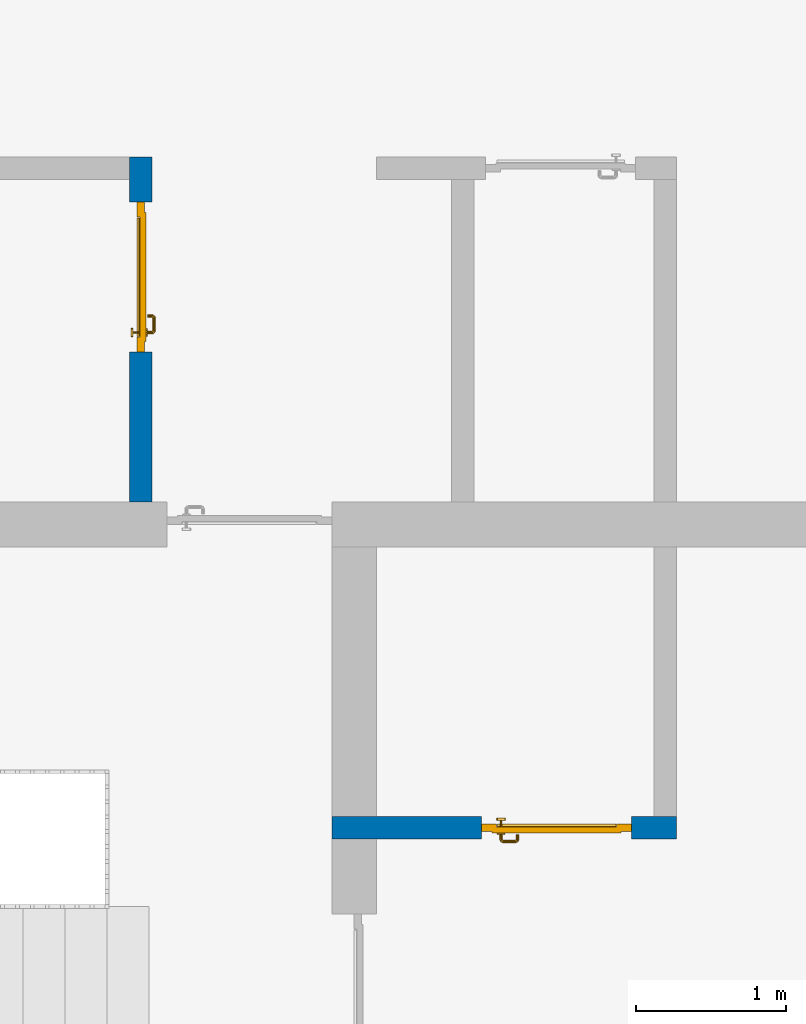
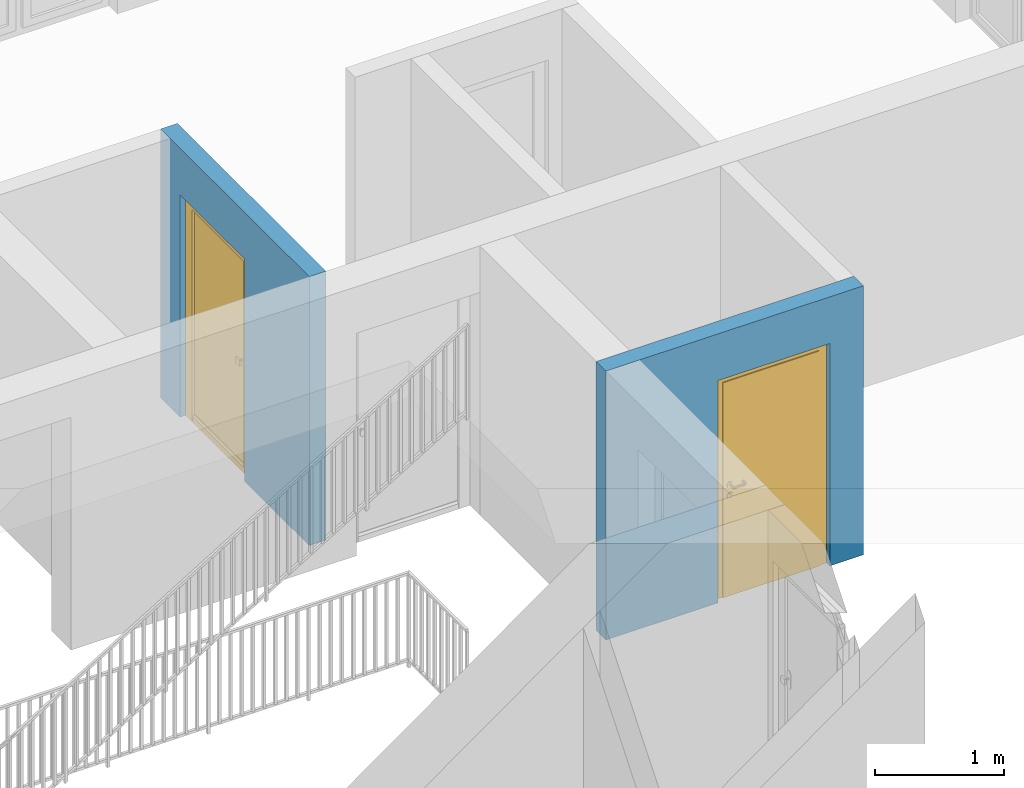
# One storey, part 16 of 48: 2 doors, 2 walls, 2 openings.
"""IFC4 building model written with IfcOpenShell, lengths in metres."""

from ifc_helpers import new_model, entity, si_unit, converted_unit, derived_unit, direction, frame, origin_with_axes, place, context, subcontext, project, spatial, polygons, source, transform, mapped, material, type_object, element, fill, save


model = new_model("IFC4")

# Units and contexts
model_context = context("Model", 3, precision=1e-05, world=origin_with_axes(), true_north=direction((0.0, 1.0)))
body_context = subcontext(model_context, "Body", "Model", "MODEL_VIEW")
ifc_project = project(units=[si_unit("LENGTHUNIT", "METRE"), si_unit("AREAUNIT", "SQUARE_METRE"), si_unit("VOLUMEUNIT", "CUBIC_METRE"), converted_unit("PLANEANGLEUNIT", "DEGREE", entity("IfcPlaneAngleMeasure", 0.0174532925199), si_unit("PLANEANGLEUNIT", "RADIAN"), dimensions=[0, 0, 0, 0, 0, 0, 0]), converted_unit("TIMEUNIT", "Year", entity("IfcTimeMeasure", 31556926.0), si_unit("TIMEUNIT", "SECOND"), dimensions=[0, 0, 1, 0, 0, 0, 0]), si_unit("MASSUNIT", "GRAM", prefix="KILO"), si_unit("THERMODYNAMICTEMPERATUREUNIT", "DEGREE_CELSIUS"), si_unit("LUMINOUSINTENSITYUNIT", "LUMEN"), si_unit("ENERGYUNIT", "JOULE", prefix="MEGA"), derived_unit("THERMALCONDUCTANCEUNIT", [(si_unit("POWERUNIT", "WATT"), 1), (si_unit("LENGTHUNIT", "METRE"), -1), (si_unit("THERMODYNAMICTEMPERATUREUNIT", "KELVIN"), -1)]), derived_unit("SPECIFICHEATCAPACITYUNIT", [(si_unit("ENERGYUNIT", "JOULE"), 1), (si_unit("MASSUNIT", "GRAM", prefix="KILO"), -1), (si_unit("THERMODYNAMICTEMPERATUREUNIT", "KELVIN"), -1)]), derived_unit("MASSDENSITYUNIT", [(si_unit("MASSUNIT", "GRAM", prefix="KILO"), 1), (si_unit("VOLUMEUNIT", "CUBIC_METRE"), -1)])], contexts=[model_context])

# Site, building, storey
site_placement = place(None, origin_with_axes())
site = spatial("IfcSite", under=ifc_project, at=site_placement, CompositionType="ELEMENT")
building_placement = place(site_placement, origin_with_axes())
building = spatial("IfcBuilding", under=site, at=building_placement, CompositionType="ELEMENT")
storey_placement = place(building_placement, frame((0.0, 0.0, 3.4), z_axis=(0.0, 0.0, 1.0), x_axis=(1.0, 0.0, 0.0)))
storey = spatial("IfcBuildingStorey", under=building, at=storey_placement, Name="1. Geschoss", CompositionType="ELEMENT", Elevation=3.4)

# Wall, opening, door
ifc_material = material()
wall_type = type_object("IfcWallType", Name="150", PredefinedType="NOTDEFINED")
wall_1_placement = place(storey_placement, frame((1.3378006196, 1.37118776896, 0.0), z_axis=(0.0, 0.0, 1.0), x_axis=(0.0, 1.0, 0.0)))
wall_1 = element("IfcWall", 1, at=wall_1_placement, inside=storey, type_object=wall_type, material=ifc_material, Name="Wand-002", PredefinedType="NOTDEFINED", context=body_context, shape_type="Tessellation", body=[
    polygons([(1.3, 0.0, 0.0), (1.3, 0.0, 2.1), (2.3, 0.0, 2.1), (2.3, 0.0, 0.0), (2.6, 0.0, 0.0), (2.6, 0.0, 2.54), (0.3, 0.0, 2.54), (0.3, 0.0, 0.0), (1.3, 0.1, 0.0), (1.3, 0.1, 2.1), (2.3, 0.1, 2.1), (2.3, 0.1, 0.0), (2.3, 0.15, 0.0), (2.6, 0.15, 0.0), (2.6, 0.15, 2.54), (0.3, 0.15, 2.54), (0.3, 0.15, 0.0), (1.3, 0.15, 0.0), (1.3, 0.15, 2.1), (2.3, 0.15, 2.1)], [[[1, 2, 3, 4, 5, 6, 7, 8]], [[2, 1, 9, 10]], [[3, 2, 10, 11]], [[4, 3, 11, 12]], [[4, 12, 13, 14, 5]], [[6, 5, 14, 15]], [[6, 15, 16, 7]], [[16, 17, 8, 7]], [[9, 1, 8, 17, 18]], [[10, 9, 18, 19]], [[11, 10, 19, 20]], [[12, 11, 20, 13]], [[14, 13, 20, 19, 18, 17, 16, 15]]], closed=True),
])
opening_1_placement = place(wall_1_placement, frame((1.8, 0.0, 0.0), z_axis=(0.0, 0.0, 1.0), x_axis=(1.0, 0.0, 0.0)))
opening_1 = element("IfcOpeningElement", 2, at=opening_1_placement, cuts=wall_1, context=body_context, identifier="Reference", shape_type="Tessellation", body=[
    polygons([(-0.5, 0.1, 0.0), (-0.5, 0.1, 2.1), (-0.5, 0.151, 2.1), (-0.5, 0.151, 0.0), (-0.5, -0.001, 0.0), (-0.5, -0.001, 2.1), (0.5, 0.1, 2.1), (0.5, 0.151, 2.1), (0.5, -0.001, 2.1), (0.5, 0.151, 0.0), (0.5, 0.1, 0.0), (0.5, -0.001, 0.0)], [[[1, 2, 3, 4]], [[2, 1, 5, 6]], [[7, 8, 3, 2, 6, 9]], [[8, 10, 4, 3]], [[1, 4, 10, 11, 12, 5]], [[6, 5, 12, 9]], [[7, 11, 10, 8]], [[11, 7, 9, 12]]], closed=True),
])
door_type = type_object("IfcDoorType", Name="Eingang 01 1-Fl 26", OperationType="SINGLE_SWING_LEFT", PredefinedType="DOOR")
shared_shape = source(origin_with_axes(), body_context, "Body", "Tessellation", [
    polygons([(-0.5, -0.05, 0.0), (-0.5, -0.05, 2.1), (-0.5, -0.03, 2.1), (-0.5, -0.03, 0.0), (-0.4, -0.05, 0.0), (-0.4, -0.05, 2.0), (-0.1301, -0.05, 2.0), (-0.0001, -0.05, 2.0), (0.4, -0.05, 2.0), (0.4, -0.05, 0.0), (0.5, -0.05, 0.0), (0.5, -0.05, 2.1), (0.5, -0.03, 2.1), (0.5, -0.03, 0.0), (0.4, -0.03, 0.0), (0.4, -0.03, 2.0), (-0.0001, -0.03, 2.0), (-0.1301, -0.03, 2.0), (-0.4, -0.03, 2.0), (-0.4, -0.03, 0.0)], [[[1, 2, 3, 4]], [[1, 5, 6, 7, 8, 9, 10, 11, 12, 2]], [[2, 12, 13, 3]], [[4, 3, 13, 14, 15, 16, 17, 18, 19, 20]], [[5, 1, 4, 20]], [[6, 5, 20, 19]], [[7, 6, 19, 18]], [[8, 7, 18, 17]], [[9, 8, 17, 16]], [[10, 9, 16, 15]], [[11, 10, 15, 14]], [[12, 11, 14, 13]]], closed=True),
    polygons([(-0.5, -0.03, 0.0), (-0.5, -0.03, 2.1), (-0.5, 0.0, 2.1), (-0.5, 0.0, 0.0), (-0.43, -0.03, 0.0), (-0.43, -0.03, 2.03), (-0.1001, -0.03, 2.03), (-0.0301, -0.03, 2.03), (0.43, -0.03, 2.03), (0.43, -0.03, 0.0), (0.5, -0.03, 0.0), (0.5, -0.03, 2.1), (0.5, 0.0, 2.1), (0.5, 0.0, 0.0), (0.43, 0.0, 0.0), (0.43, 0.0, 2.03), (-0.0301, 0.0, 2.03), (-0.1001, 0.0, 2.03), (-0.43, 0.0, 2.03), (-0.43, 0.0, 0.0)], [[[1, 2, 3, 4]], [[1, 5, 6, 7, 8, 9, 10, 11, 12, 2]], [[2, 12, 13, 3]], [[4, 3, 13, 14, 15, 16, 17, 18, 19, 20]], [[5, 1, 4, 20]], [[6, 5, 20, 19]], [[7, 6, 19, 18]], [[8, 7, 18, 17]], [[9, 8, 17, 16]], [[10, 9, 16, 15]], [[11, 10, 15, 14]], [[12, 11, 14, 13]]], closed=True),
    polygons([(-0.43, 0.01, 0.0), (-0.43, 0.01, 2.03), (0.43, 0.01, 2.03), (0.43, 0.01, 0.0), (-0.43, -0.03, 0.0), (-0.43, -0.03, 2.03), (0.43, -0.03, 2.03), (0.43, -0.03, 0.0)], [[[1, 2, 3, 4]], [[1, 5, 6, 2]], [[2, 6, 7, 3]], [[3, 7, 8, 4]], [[4, 8, 5, 1]], [[8, 7, 6, 5]]], closed=True),
    polygons([(-0.395, -0.05, 0.0), (0.395, -0.05, 0.0), (0.395, -0.05, 0.05), (-0.395, -0.05, 0.05), (-0.395, -0.03, 0.0), (0.395, -0.03, 0.0), (0.395, -0.03, 0.07), (0.395, -0.035, 0.07), (-0.395, -0.035, 0.07), (-0.395, -0.03, 0.07)], [[[1, 2, 3, 4]], [[5, 6, 2, 1]], [[2, 6, 7, 8, 3]], [[4, 3, 8, 9]], [[1, 4, 9, 10, 5]], [[10, 7, 6, 5]], [[9, 8, 7, 10]]], closed=True),
    polygons([(0.3835, 0.02, 1.0733826859), (0.37, 0.02, 1.077), (0.37, 0.0199, 1.077), (0.3835, 0.0199, 1.0733826859), (0.393382685902, 0.02, 1.0635), (0.397, 0.02, 1.05), (0.393382685902, 0.02, 1.0365), (0.3835, 0.02, 1.0266173141), (0.37, 0.02, 1.023), (0.3565, 0.02, 1.0266173141), (0.346617314098, 0.02, 1.0365), (0.343, 0.02, 1.05), (0.346617314098, 0.02, 1.0635), (0.3565, 0.02, 1.0733826859), (0.3565, 0.0199, 1.0733826859), (0.37, 0.0101, 1.077), (0.3835, 0.0101, 1.0733826859), (0.393382685902, 0.0199, 1.0635), (0.397, 0.0199, 1.05), (0.393382685902, 0.0199, 1.0365), (0.3835, 0.0199, 1.0266173141), (0.37, 0.0199, 1.023), (0.3565, 0.0199, 1.0266173141), (0.346617314098, 0.0199, 1.0365), (0.343, 0.0199, 1.05), (0.346617314098, 0.0199, 1.0635), (0.3565, 0.0101, 1.0733826859), (0.37, 0.01, 1.077), (0.3835, 0.01, 1.0733826859), (0.393382685902, 0.0101, 1.0635), (0.397, 0.0101, 1.05), (0.393382685902, 0.0101, 1.0365), (0.3835, 0.0101, 1.0266173141), (0.37, 0.0101, 1.023), (0.3565, 0.0101, 1.0266173141), (0.346617314098, 0.0101, 1.0365), (0.343, 0.0101, 1.05), (0.346617314098, 0.0101, 1.0635), (0.3565, 0.01, 1.0733826859), (0.346617314098, 0.01, 1.0635), (0.343, 0.01, 1.05), (0.346617314098, 0.01, 1.0365), (0.3565, 0.01, 1.0266173141), (0.37, 0.01, 1.023), (0.3835, 0.01, 1.0266173141), (0.393382685902, 0.01, 1.0365), (0.397, 0.01, 1.05), (0.393382685902, 0.01, 1.0635)], [[[1, 2, 3, 4]], [[2, 1, 5, 6, 7, 8, 9, 10, 11, 12, 13, 14]], [[2, 14, 15, 3]], [[4, 3, 16, 17]], [[5, 1, 4, 18]], [[6, 5, 18, 19]], [[7, 6, 19, 20]], [[8, 7, 20, 21]], [[9, 8, 21, 22]], [[10, 9, 22, 23]], [[11, 10, 23, 24]], [[12, 11, 24, 25]], [[13, 12, 25, 26]], [[14, 13, 26, 15]], [[3, 15, 27, 16]], [[17, 16, 28, 29]], [[18, 4, 17, 30]], [[19, 18, 30, 31]], [[20, 19, 31, 32]], [[21, 20, 32, 33]], [[22, 21, 33, 34]], [[23, 22, 34, 35]], [[24, 23, 35, 36]], [[25, 24, 36, 37]], [[26, 25, 37, 38]], [[15, 26, 38, 27]], [[16, 27, 39, 28]], [[28, 39, 40, 41, 42, 43, 44, 45, 46, 47, 48, 29]], [[30, 17, 29, 48]], [[31, 30, 48, 47]], [[32, 31, 47, 46]], [[33, 32, 46, 45]], [[34, 33, 45, 44]], [[35, 34, 44, 43]], [[36, 35, 43, 42]], [[37, 36, 42, 41]], [[38, 37, 41, 40]], [[27, 38, 40, 39]]], closed=True),
    polygons([(0.362532169224, 0.019, 0.959692280177), (0.363279754556, 0.019, 0.961639806549), (0.35705, 0.019, 0.972430057958), (0.347569942042, 0.019, 0.96295), (0.365, 0.019, 0.952886751346), (0.365, 0.019, 0.9544), (0.362532169224, 0.02, 0.959692280177), (0.363279754556, 0.02, 0.961639806549), (0.364624817685, 0.02, 0.965143815798), (0.364624817685, 0.019, 0.965143815798), (0.37, 0.019, 0.967425445323), (0.37, 0.019, 0.9759), (0.357, 0.019, 0.972516660498), (0.347483339502, 0.019, 0.963), (0.365, 0.019, 0.95), (0.3441, 0.019, 0.95), (0.365, 0.019, 0.947113248654), (0.365, 0.019, 0.941339745962), (0.365, 0.019, 0.9375), (0.365, 0.02, 0.9375), (0.365, 0.02, 0.941339745962), (0.365, 0.02, 0.947113248654), (0.365, 0.02, 0.95), (0.365, 0.02, 0.952886751346), (0.365, 0.02, 0.9544), (0.346703916638, 0.02, 0.96345), (0.35655, 0.02, 0.973296083362), (0.37, 0.02, 0.9769), (0.37, 0.02, 0.967425445323), (0.375375182315, 0.019, 0.965143815798), (0.376720245444, 0.019, 0.961639806549), (0.38295, 0.019, 0.972430057958), (0.37, 0.019, 0.976), (0.357, 0.0189, 0.972516660498), (0.347483339502, 0.0189, 0.963), (0.344, 0.019, 0.95), (0.347569942042, 0.019, 0.93705), (0.35705, 0.019, 0.927569942042), (0.37, 0.019, 0.9241), (0.37, 0.019, 0.9325), (0.366464466094, 0.019, 0.933964466094), (0.366464466094, 0.02, 0.933964466094), (0.37, 0.02, 0.9231), (0.35655, 0.02, 0.926703916638), (0.37, 0.02, 0.9325), (0.346703916638, 0.02, 0.93655), (0.3431, 0.02, 0.95), (0.346617314098, 0.02, 0.9635), (0.3565, 0.02, 0.973382685902), (0.37, 0.02, 0.977), (0.375375182315, 0.02, 0.965143815798), (0.38345, 0.02, 0.973296083362), (0.376720245444, 0.02, 0.961639806549), (0.377467830776, 0.02, 0.959692280177), (0.377467830776, 0.019, 0.959692280177), (0.375, 0.019, 0.9544), (0.375, 0.019, 0.952886751346), (0.392430057958, 0.019, 0.96295), (0.383, 0.019, 0.972516660498), (0.37, 0.0189, 0.976), (0.357, 0.0101, 0.972516660498), (0.347483339502, 0.0101, 0.963), (0.344, 0.0189, 0.95), (0.347483339502, 0.019, 0.937), (0.357, 0.019, 0.927483339502), (0.37, 0.019, 0.924), (0.38295, 0.019, 0.927569942042), (0.375, 0.019, 0.941339745962), (0.375, 0.019, 0.9375), (0.373535533906, 0.019, 0.933964466094), (0.37, 0.02, 0.923), (0.3565, 0.02, 0.926617314098), (0.38345, 0.02, 0.926703916638), (0.373535533906, 0.02, 0.933964466094), (0.375, 0.02, 0.9375), (0.375, 0.02, 0.941339745962), (0.346617314098, 0.02, 0.9365), (0.343, 0.02, 0.95), (0.346617314098, 0.0199, 0.9635), (0.3565, 0.0199, 0.973382685902), (0.37, 0.0199, 0.977), (0.3835, 0.02, 0.973382685902), (0.393296083362, 0.02, 0.96345), (0.375, 0.02, 0.952886751346), (0.375, 0.02, 0.9544), (0.375, 0.02, 0.95), (0.375, 0.02, 0.947113248654), (0.375, 0.019, 0.947113248654), (0.375, 0.019, 0.95), (0.3959, 0.019, 0.95), (0.392516660498, 0.019, 0.963), (0.383, 0.0189, 0.972516660498), (0.37, 0.0101, 0.976), (0.357, 0.01, 0.972516660498), (0.347483339502, 0.01, 0.963), (0.344, 0.0101, 0.95), (0.347483339502, 0.0189, 0.937), (0.357, 0.0189, 0.927483339502), (0.37, 0.0189, 0.924), (0.383, 0.019, 0.927483339502), (0.392430057958, 0.019, 0.93705), (0.37, 0.0199, 0.923), (0.3565, 0.0199, 0.926617314098), (0.3835, 0.02, 0.926617314098), (0.393296083362, 0.02, 0.93655), (0.346617314098, 0.0199, 0.9365), (0.343, 0.0199, 0.95), (0.346617314098, 0.0101, 0.9635), (0.3565, 0.0101, 0.973382685902), (0.37, 0.0101, 0.977), (0.3835, 0.0199, 0.973382685902), (0.393382685902, 0.02, 0.9635), (0.3969, 0.02, 0.95), (0.396, 0.019, 0.95), (0.392516660498, 0.0189, 0.963), (0.383, 0.0101, 0.972516660498), (0.37, 0.01, 0.976), (0.35695, 0.01, 0.972603263039), (0.347396736961, 0.01, 0.96305), (0.344, 0.01, 0.95), (0.347483339502, 0.0101, 0.937), (0.357, 0.0101, 0.927483339502), (0.37, 0.0101, 0.924), (0.383, 0.0189, 0.927483339502), (0.392516660498, 0.019, 0.937), (0.37, 0.0101, 0.923), (0.3565, 0.0101, 0.926617314098), (0.3835, 0.0199, 0.926617314098), (0.393382685902, 0.02, 0.9365), (0.346617314098, 0.0101, 0.9365), (0.343, 0.0101, 0.95), (0.346617314098, 0.01, 0.9635), (0.3565, 0.01, 0.973382685902), (0.37, 0.01, 0.977), (0.3835, 0.0101, 0.973382685902), (0.393382685902, 0.0199, 0.9635), (0.397, 0.02, 0.95), (0.396, 0.0189, 0.95), (0.392516660498, 0.0101, 0.963), (0.383, 0.01, 0.972516660498), (0.37, 0.01, 0.9761), (0.35655, 0.01, 0.973296083362), (0.346703916638, 0.01, 0.96345), (0.3439, 0.01, 0.95), (0.347483339502, 0.01, 0.937), (0.357, 0.01, 0.927483339502), (0.37, 0.01, 0.924), (0.383, 0.0101, 0.927483339502), (0.392516660498, 0.0189, 0.937), (0.37, 0.01, 0.923), (0.3565, 0.01, 0.926617314098), (0.3835, 0.0101, 0.926617314098), (0.393382685902, 0.0199, 0.9365), (0.346617314098, 0.01, 0.9365), (0.343, 0.01, 0.95), (0.37, 0.01, 0.9769), (0.3835, 0.01, 0.973382685902), (0.393382685902, 0.0101, 0.9635), (0.397, 0.0199, 0.95), (0.396, 0.0101, 0.95), (0.392516660498, 0.01, 0.963), (0.38305, 0.01, 0.972603263039), (0.3431, 0.01, 0.95), (0.347396736961, 0.01, 0.93695), (0.35695, 0.01, 0.927396736961), (0.37, 0.01, 0.9239), (0.383, 0.01, 0.927483339502), (0.392516660498, 0.0101, 0.937), (0.37, 0.01, 0.9231), (0.35655, 0.01, 0.926703916638), (0.3835, 0.01, 0.926617314098), (0.393382685902, 0.0101, 0.9365), (0.346703916638, 0.01, 0.93655), (0.38345, 0.01, 0.973296083362), (0.393382685902, 0.01, 0.9635), (0.397, 0.0101, 0.95), (0.396, 0.01, 0.95), (0.392603263039, 0.01, 0.96305), (0.38305, 0.01, 0.927396736961), (0.392516660498, 0.01, 0.937), (0.38345, 0.01, 0.926703916638), (0.393382685902, 0.01, 0.9365), (0.393296083362, 0.01, 0.96345), (0.397, 0.01, 0.95), (0.3961, 0.01, 0.95), (0.392603263039, 0.01, 0.93695), (0.393296083362, 0.01, 0.93655), (0.3969, 0.01, 0.95)], [[[1, 2, 3, 4, 5, 6]], [[1, 7, 8, 9, 10, 2]], [[10, 11, 12, 3, 2]], [[4, 3, 13, 14]], [[15, 5, 4, 16]], [[6, 5, 15, 17, 18, 19, 20, 21, 22, 23, 24, 25]], [[6, 25, 7, 1]], [[7, 25, 24, 26, 27, 8]], [[9, 8, 27, 28, 29]], [[10, 9, 29, 11]], [[30, 31, 32, 12, 11]], [[3, 12, 33, 13]], [[14, 13, 34, 35]], [[16, 4, 14, 36]], [[17, 15, 16, 37]], [[18, 17, 37, 38]], [[38, 39, 40, 41, 19, 18]], [[19, 41, 42, 20]], [[43, 44, 21, 20, 42, 45]], [[22, 21, 44, 46]], [[23, 22, 46, 47]], [[24, 23, 47, 26]], [[48, 49, 27, 26]], [[49, 50, 28, 27]], [[51, 29, 28, 52, 53]], [[11, 29, 51, 30]], [[30, 51, 53, 54, 55, 31]], [[55, 56, 57, 58, 32, 31]], [[12, 32, 59, 33]], [[13, 33, 60, 34]], [[35, 34, 61, 62]], [[36, 14, 35, 63]], [[37, 16, 36, 64]], [[38, 37, 64, 65]], [[39, 38, 65, 66]], [[39, 67, 68, 69, 70, 40]], [[41, 40, 45, 42]], [[71, 72, 44, 43]], [[73, 43, 45, 74, 75, 76]], [[72, 77, 46, 44]], [[77, 78, 47, 46]], [[78, 48, 26, 47]], [[79, 80, 49, 48]], [[80, 81, 50, 49]], [[50, 82, 52, 28]], [[54, 53, 52, 83, 84, 85]], [[55, 54, 85, 56]], [[85, 84, 86, 87, 76, 75, 69, 68, 88, 89, 57, 56]], [[57, 89, 90, 58]], [[32, 58, 91, 59]], [[33, 59, 92, 60]], [[34, 60, 93, 61]], [[62, 61, 94, 95]], [[63, 35, 62, 96]], [[64, 36, 63, 97]], [[65, 64, 97, 98]], [[66, 65, 98, 99]], [[67, 39, 66, 100]], [[88, 68, 67, 101]], [[70, 69, 75, 74]], [[40, 70, 74, 45]], [[102, 103, 72, 71]], [[104, 71, 43, 73]], [[76, 87, 105, 73]], [[103, 106, 77, 72]], [[106, 107, 78, 77]], [[107, 79, 48, 78]], [[108, 109, 80, 79]], [[109, 110, 81, 80]], [[81, 111, 82, 50]], [[82, 112, 83, 52]], [[86, 84, 83, 113]], [[87, 86, 113, 105]], [[89, 88, 101, 90]], [[58, 90, 114, 91]], [[59, 91, 115, 92]], [[60, 92, 116, 93]], [[61, 93, 117, 94]], [[95, 94, 118, 119]], [[96, 62, 95, 120]], [[97, 63, 96, 121]], [[98, 97, 121, 122]], [[99, 98, 122, 123]], [[100, 66, 99, 124]], [[101, 67, 100, 125]], [[126, 127, 103, 102]], [[128, 102, 71, 104]], [[129, 104, 73, 105]], [[127, 130, 106, 103]], [[130, 131, 107, 106]], [[131, 108, 79, 107]], [[132, 133, 109, 108]], [[133, 134, 110, 109]], [[110, 135, 111, 81]], [[111, 136, 112, 82]], [[112, 137, 113, 83]], [[137, 129, 105, 113]], [[90, 101, 125, 114]], [[91, 114, 138, 115]], [[92, 115, 139, 116]], [[93, 116, 140, 117]], [[94, 117, 141, 118]], [[119, 118, 142, 143]], [[120, 95, 119, 144]], [[121, 96, 120, 145]], [[122, 121, 145, 146]], [[123, 122, 146, 147]], [[124, 99, 123, 148]], [[125, 100, 124, 149]], [[150, 151, 127, 126]], [[152, 126, 102, 128]], [[153, 128, 104, 129]], [[151, 154, 130, 127]], [[154, 155, 131, 130]], [[155, 132, 108, 131]], [[143, 142, 133, 132]], [[142, 156, 134, 133]], [[134, 157, 135, 110]], [[135, 158, 136, 111]], [[136, 159, 137, 112]], [[159, 153, 129, 137]], [[114, 125, 149, 138]], [[115, 138, 160, 139]], [[116, 139, 161, 140]], [[117, 140, 162, 141]], [[118, 141, 156, 142]], [[144, 119, 143, 163]], [[145, 120, 144, 164]], [[146, 145, 164, 165]], [[147, 146, 165, 166]], [[148, 123, 147, 167]], [[149, 124, 148, 168]], [[169, 170, 151, 150]], [[171, 150, 126, 152]], [[172, 152, 128, 153]], [[170, 173, 154, 151]], [[173, 163, 155, 154]], [[163, 143, 132, 155]], [[156, 174, 157, 134]], [[157, 175, 158, 135]], [[158, 176, 159, 136]], [[176, 172, 153, 159]], [[138, 149, 168, 160]], [[139, 160, 177, 161]], [[140, 161, 178, 162]], [[141, 162, 174, 156]], [[164, 144, 163, 173]], [[165, 164, 173, 170]], [[166, 165, 170, 169]], [[167, 147, 166, 179]], [[168, 148, 167, 180]], [[181, 169, 150, 171]], [[182, 171, 152, 172]], [[174, 183, 175, 157]], [[175, 184, 176, 158]], [[184, 182, 172, 176]], [[160, 168, 180, 177]], [[161, 177, 185, 178]], [[162, 178, 183, 174]], [[179, 166, 169, 181]], [[180, 167, 179, 186]], [[187, 181, 171, 182]], [[183, 188, 184, 175]], [[188, 187, 182, 184]], [[177, 180, 186, 185]], [[178, 185, 188, 183]], [[186, 179, 181, 187]], [[185, 186, 187, 188]]], closed=True),
    polygons([(0.38, 0.02, 1.05), (0.377071067812, 0.02, 1.04292893219), (0.377071067812, 0.050696439392, 1.04292893219), (0.38, 0.0509849140336, 1.05), (0.37, 0.02, 1.04), (0.37, 0.05, 1.04), (0.375518993221, 0.0584992452783, 1.04292893219), (0.378277987014, 0.0596420579258, 1.05), (0.377071067812, 0.02, 1.05707106781), (0.377071067812, 0.050696439392, 1.05707106781), (0.362928932188, 0.02, 1.04292893219), (0.362928932188, 0.049303560608, 1.04292893219), (0.368858192988, 0.0557402514855, 1.04), (0.370704557509, 0.0657045575088, 1.04292893219), (0.372816199938, 0.0678161999379, 1.05), (0.375518993221, 0.0584992452783, 1.05707106781), (0.37, 0.02, 1.06), (0.37, 0.05, 1.06), (0.36, 0.02, 1.05), (0.36, 0.0490150859664, 1.05), (0.362197392755, 0.0529812576926, 1.04292893219), (0.365606601718, 0.0606066017178, 1.04), (0.363499245278, 0.0705189932208, 1.04292893219), (0.364642057926, 0.0732779870137, 1.05), (0.370704557509, 0.0657045575088, 1.05707106781), (0.368858192988, 0.0557402514855, 1.06), (0.362928932188, 0.02, 1.05707106781), (0.362928932188, 0.049303560608, 1.05707106781), (0.359438398962, 0.0518384450452, 1.05), (0.360508645927, 0.0555086459268, 1.04292893219), (0.360740251485, 0.0638581929877, 1.04), (0.355696439392, 0.0720710678119, 1.04292893219), (0.355984914034, 0.075, 1.05), (0.363499245278, 0.0705189932208, 1.05707106781), (0.365606601718, 0.0606066017178, 1.06), (0.362197392755, 0.0529812576926, 1.05707106781), (0.358397003498, 0.0533970034977, 1.05), (0.357981257693, 0.0571973927545, 1.04292893219), (0.355, 0.065, 1.04), (0.274303560608, 0.0720710678119, 1.04292893219), (0.274015085966, 0.075, 1.05), (0.355696439392, 0.0720710678119, 1.05707106781), (0.360740251485, 0.0638581929877, 1.06), (0.360508645927, 0.0555086459268, 1.05707106781), (0.356838445045, 0.0544383989617, 1.05), (0.354303560608, 0.0579289321881, 1.04292893219), (0.275, 0.065, 1.04), (0.266500754722, 0.0705189932208, 1.04292893219), (0.265357942074, 0.0732779870137, 1.05), (0.274303560608, 0.0720710678119, 1.05707106781), (0.355, 0.065, 1.06), (0.357981257693, 0.0571973927545, 1.05707106781), (0.354015085966, 0.055, 1.05), (0.275696439392, 0.0579289321881, 1.04292893219), (0.269259748515, 0.0638581929877, 1.04), (0.259295442491, 0.0657045575088, 1.04292893219), (0.257183800062, 0.0678161999379, 1.05), (0.266500754722, 0.0705189932208, 1.05707106781), (0.275, 0.065, 1.06), (0.354303560608, 0.0579289321881, 1.05707106781), (0.275984914034, 0.055, 1.05), (0.272018742307, 0.0571973927545, 1.04292893219), (0.264393398282, 0.0606066017178, 1.04), (0.254481006779, 0.0584992452783, 1.04292893219), (0.251722012986, 0.0596420579258, 1.05), (0.259295442491, 0.0657045575088, 1.05707106781), (0.269259748515, 0.0638581929877, 1.06), (0.275696439392, 0.0579289321881, 1.05707106781), (0.273161554955, 0.0544383989617, 1.05), (0.269491354073, 0.0555086459268, 1.04292893219), (0.261141807012, 0.0557402514855, 1.04), (0.252928932188, 0.050696439392, 1.04292893219), (0.25, 0.0509849140336, 1.05), (0.254481006779, 0.0584992452783, 1.05707106781), (0.264393398282, 0.0606066017178, 1.06), (0.272018742307, 0.0571973927545, 1.05707106781), (0.271602996502, 0.0533970034977, 1.05), (0.267802607245, 0.0529812576926, 1.04292893219), (0.26, 0.05, 1.04), (0.252928932188, 0.02, 1.04292893219), (0.25, 0.02, 1.05), (0.252928932188, 0.050696439392, 1.05707106781), (0.261141807012, 0.0557402514855, 1.06), (0.269491354073, 0.0555086459268, 1.05707106781), (0.270561601038, 0.0518384450452, 1.05), (0.267071067812, 0.049303560608, 1.04292893219), (0.26, 0.02, 1.04), (0.267071067812, 0.02, 1.04292893219), (0.27, 0.02, 1.05), (0.267071067812, 0.02, 1.05707106781), (0.26, 0.02, 1.06), (0.252928932188, 0.02, 1.05707106781), (0.26, 0.05, 1.06), (0.267802607245, 0.0529812576926, 1.05707106781), (0.27, 0.0490150859664, 1.05), (0.267071067812, 0.049303560608, 1.05707106781)], [[[1, 2, 3, 4]], [[2, 5, 6, 3]], [[4, 3, 7, 8]], [[9, 1, 4, 10]], [[5, 11, 12, 6]], [[3, 6, 13, 7]], [[8, 7, 14, 15]], [[10, 4, 8, 16]], [[17, 9, 10, 18]], [[11, 19, 20, 12]], [[6, 12, 21, 13]], [[7, 13, 22, 14]], [[15, 14, 23, 24]], [[16, 8, 15, 25]], [[18, 10, 16, 26]], [[27, 17, 18, 28]], [[19, 27, 28, 20]], [[12, 20, 29, 21]], [[13, 21, 30, 22]], [[14, 22, 31, 23]], [[24, 23, 32, 33]], [[25, 15, 24, 34]], [[26, 16, 25, 35]], [[28, 18, 26, 36]], [[20, 28, 36, 29]], [[21, 29, 37, 30]], [[22, 30, 38, 31]], [[23, 31, 39, 32]], [[33, 32, 40, 41]], [[34, 24, 33, 42]], [[35, 25, 34, 43]], [[36, 26, 35, 44]], [[29, 36, 44, 37]], [[30, 37, 45, 38]], [[31, 38, 46, 39]], [[32, 39, 47, 40]], [[41, 40, 48, 49]], [[42, 33, 41, 50]], [[43, 34, 42, 51]], [[44, 35, 43, 52]], [[37, 44, 52, 45]], [[38, 45, 53, 46]], [[39, 46, 54, 47]], [[40, 47, 55, 48]], [[49, 48, 56, 57]], [[50, 41, 49, 58]], [[51, 42, 50, 59]], [[52, 43, 51, 60]], [[45, 52, 60, 53]], [[46, 53, 61, 54]], [[47, 54, 62, 55]], [[48, 55, 63, 56]], [[57, 56, 64, 65]], [[58, 49, 57, 66]], [[59, 50, 58, 67]], [[60, 51, 59, 68]], [[53, 60, 68, 61]], [[54, 61, 69, 62]], [[55, 62, 70, 63]], [[56, 63, 71, 64]], [[65, 64, 72, 73]], [[66, 57, 65, 74]], [[67, 58, 66, 75]], [[68, 59, 67, 76]], [[61, 68, 76, 69]], [[62, 69, 77, 70]], [[63, 70, 78, 71]], [[64, 71, 79, 72]], [[73, 72, 80, 81]], [[74, 65, 73, 82]], [[75, 66, 74, 83]], [[76, 67, 75, 84]], [[69, 76, 84, 77]], [[70, 77, 85, 78]], [[71, 78, 86, 79]], [[72, 79, 87, 80]], [[81, 80, 87, 88, 89, 90, 91, 92]], [[82, 73, 81, 92]], [[83, 74, 82, 93]], [[84, 75, 83, 94]], [[77, 84, 94, 85]], [[78, 85, 95, 86]], [[79, 86, 88, 87]], [[86, 95, 89, 88]], [[95, 96, 90, 89]], [[96, 93, 91, 90]], [[93, 82, 92, 91]], [[94, 83, 93, 96]], [[85, 94, 96, 95]]], closed=False),
    polygons([(0.364696699141, -0.035, 1.04469669914), (0.3625, -0.035, 1.05), (0.364696699141, -0.035, 1.05530330086), (0.37, -0.035, 1.0575), (0.375303300859, -0.035, 1.05530330086), (0.3775, -0.035, 1.05), (0.375303300859, -0.035, 1.04469669914), (0.37, -0.035, 1.0425), (0.364696699141, -0.075, 1.04469669914), (0.3625, -0.075, 1.05), (0.364696699141, -0.075, 1.05530330086), (0.37, -0.075, 1.0575), (0.375303300859, -0.075, 1.05530330086), (0.3775, -0.075, 1.05), (0.375303300859, -0.075, 1.04469669914), (0.37, -0.075, 1.0425)], [[[1, 2, 3, 4, 5, 6, 7, 8]], [[1, 9, 10, 2]], [[2, 10, 11, 3]], [[3, 11, 12, 4]], [[4, 12, 13, 5]], [[5, 13, 14, 6]], [[6, 14, 15, 7]], [[7, 15, 16, 8]], [[8, 16, 9, 1]], [[9, 16, 15, 14, 13, 12, 11, 10]]], closed=True),
    polygons([(0.395, -0.03, 0.975), (0.395, -0.035, 0.975), (0.393096988313, -0.035, 0.965432914191), (0.393096988313, -0.03, 0.965432914191), (0.395, -0.03, 1.1), (0.395, -0.035, 1.1), (0.393096988313, -0.035, 1.10956708581), (0.38767766953, -0.035, 1.11767766953), (0.379567085809, -0.035, 1.12309698831), (0.37, -0.035, 1.125), (0.360432914191, -0.035, 1.12309698831), (0.35232233047, -0.035, 1.11767766953), (0.346903011687, -0.035, 1.10956708581), (0.345, -0.035, 1.1), (0.345, -0.035, 0.975), (0.346903011687, -0.035, 0.965432914191), (0.35232233047, -0.035, 0.95732233047), (0.360432914191, -0.035, 0.951903011687), (0.37, -0.035, 0.95), (0.379567085809, -0.035, 0.951903011687), (0.38767766953, -0.035, 0.95732233047), (0.38767766953, -0.03, 0.95732233047), (0.379567085809, -0.03, 0.951903011687), (0.37, -0.03, 0.95), (0.360432914191, -0.03, 0.951903011687), (0.35232233047, -0.03, 0.95732233047), (0.346903011687, -0.03, 0.965432914191), (0.345, -0.03, 0.975), (0.345, -0.03, 1.1), (0.346903011687, -0.03, 1.10956708581), (0.35232233047, -0.03, 1.11767766953), (0.360432914191, -0.03, 1.12309698831), (0.37, -0.03, 1.125), (0.379567085809, -0.03, 1.12309698831), (0.38767766953, -0.03, 1.11767766953), (0.393096988313, -0.03, 1.10956708581)], [[[1, 2, 3, 4]], [[5, 6, 2, 1]], [[2, 6, 7, 8, 9, 10, 11, 12, 13, 14, 15, 16, 17, 18, 19, 20, 21, 3]], [[4, 3, 21, 22]], [[1, 4, 22, 23, 24, 25, 26, 27, 28, 29, 30, 31, 32, 33, 34, 35, 36, 5]], [[36, 7, 6, 5]], [[35, 8, 7, 36]], [[34, 9, 8, 35]], [[33, 10, 9, 34]], [[32, 11, 10, 33]], [[31, 12, 11, 32]], [[30, 13, 12, 31]], [[29, 14, 13, 30]], [[28, 15, 14, 29]], [[27, 16, 15, 28]], [[26, 17, 16, 27]], [[25, 18, 17, 26]], [[24, 19, 18, 25]], [[23, 20, 19, 24]], [[22, 21, 20, 23]]], closed=True),
    polygons([(0.39, -0.075, 1.08), (0.39, -0.09, 1.08), (0.395, -0.09, 1.07866025404), (0.395, -0.075, 1.07866025404), (0.35, -0.075, 1.08), (0.35, -0.09, 1.08), (0.345, -0.09, 1.07866025404), (0.341339745962, -0.09, 1.075), (0.34, -0.09, 1.07), (0.34, -0.09, 1.03), (0.341339745962, -0.09, 1.025), (0.345, -0.09, 1.02133974596), (0.35, -0.09, 1.02), (0.39, -0.09, 1.02), (0.395, -0.09, 1.02133974596), (0.398660254038, -0.09, 1.025), (0.4, -0.09, 1.03), (0.4, -0.09, 1.07), (0.398660254038, -0.09, 1.075), (0.398660254038, -0.075, 1.075), (0.4, -0.075, 1.07), (0.4, -0.075, 1.03), (0.398660254038, -0.075, 1.025), (0.395, -0.075, 1.02133974596), (0.39, -0.075, 1.02), (0.35, -0.075, 1.02), (0.345, -0.075, 1.02133974596), (0.341339745962, -0.075, 1.025), (0.34, -0.075, 1.03), (0.34, -0.075, 1.07), (0.341339745962, -0.075, 1.075), (0.345, -0.075, 1.07866025404)], [[[1, 2, 3, 4]], [[5, 6, 2, 1]], [[2, 6, 7, 8, 9, 10, 11, 12, 13, 14, 15, 16, 17, 18, 19, 3]], [[4, 3, 19, 20]], [[1, 4, 20, 21, 22, 23, 24, 25, 26, 27, 28, 29, 30, 31, 32, 5]], [[32, 7, 6, 5]], [[31, 8, 7, 32]], [[30, 9, 8, 31]], [[29, 10, 9, 30]], [[28, 11, 10, 29]], [[27, 12, 11, 28]], [[26, 13, 12, 27]], [[25, 14, 13, 26]], [[24, 15, 14, 25]], [[23, 16, 15, 24]], [[22, 17, 16, 23]], [[21, 18, 17, 22]], [[20, 19, 18, 21]]], closed=True),
])
door_1_placement = place(opening_1_placement, frame((0.4, 0.0, 0.0), z_axis=(0.0, 0.0, 1.0), x_axis=(-1.0, 0.0, 0.0)))
door_1 = element("IfcDoor", 3, at=door_1_placement, inside=storey, type_object=door_type, OverallHeight=2.1, OverallWidth=1.0, PredefinedType="DOOR", context=body_context, shape_type="MappedRepresentation", body=[
    mapped(shared_shape, transform((0.4, -0.05, 0.0))),
])
fill(opening_1, door_1)

wall_2_placement = place(storey_placement, frame((2.5378006196, -0.428812231043, 0.0), z_axis=(0.0, 0.0, 1.0), x_axis=(1.0, 0.0, 0.0)))
wall_2 = element("IfcWall", 4, at=wall_2_placement, inside=storey, type_object=wall_type, material=ifc_material, Name="Wand-002", PredefinedType="NOTDEFINED", context=body_context, shape_type="Tessellation", body=[
    polygons([(2.0, -0.05, 0.0), (2.0, -0.05, 2.1), (2.0, 0.0, 2.1), (2.0, 0.0, 0.0), (2.0, -0.15, 0.0), (2.0, -0.15, 2.1), (1.0, -0.05, 2.1), (1.0, 0.0, 2.1), (2.3, 0.0, 0.0), (1.0, 0.0, 0.0), (0.0, 0.0, 0.0), (0.0, 0.0, 2.54), (2.3, 0.0, 2.54), (2.3, -0.15, 0.0), (2.3, -0.15, 2.54), (0.0, -0.15, 2.54), (0.0, -0.15, 0.0), (1.0, -0.15, 0.0), (1.0, -0.15, 2.1), (1.0, -0.05, 0.0)], [[[1, 2, 3, 4]], [[2, 1, 5, 6]], [[2, 7, 8, 3]], [[9, 4, 3, 8, 10, 11, 12, 13]], [[5, 1, 4, 9, 14]], [[6, 5, 14, 15, 16, 17, 18, 19]], [[7, 2, 6, 19]], [[7, 20, 10, 8]], [[20, 18, 17, 11, 10]], [[12, 11, 17, 16]], [[13, 12, 16, 15]], [[15, 14, 9, 13]], [[20, 7, 19, 18]]], closed=True),
])
opening_2_placement = place(wall_2_placement, frame((1.5, 0.0, 0.0), z_axis=(0.0, 0.0, 1.0), x_axis=(1.0, 0.0, 0.0)))
opening_2 = element("IfcOpeningElement", 5, at=opening_2_placement, cuts=wall_2, context=body_context, identifier="Reference", shape_type="Tessellation", body=[
    polygons([(-0.5, -0.05, 0.0), (-0.5, -0.05, 2.1), (-0.5, 0.001, 2.1), (-0.5, 0.001, 0.0), (-0.5, -0.151, 0.0), (-0.5, -0.151, 2.1), (0.5, -0.05, 2.1), (0.5, 0.001, 2.1), (0.5, -0.151, 2.1), (0.5, 0.001, 0.0), (0.5, -0.05, 0.0), (0.5, -0.151, 0.0)], [[[1, 2, 3, 4]], [[2, 1, 5, 6]], [[7, 8, 3, 2, 6, 9]], [[8, 10, 4, 3]], [[1, 4, 10, 11, 12, 5]], [[6, 5, 12, 9]], [[7, 11, 10, 8]], [[11, 7, 9, 12]]], closed=True),
])
door_2_placement = place(opening_2_placement, frame((0.4, 0.0, 0.0), z_axis=(0.0, 0.0, 1.0), x_axis=(-1.0, 0.0, 0.0)))
door_2 = element("IfcDoor", 6, at=door_2_placement, inside=storey, type_object=door_type, OverallHeight=2.1, OverallWidth=1.0, PredefinedType="DOOR", context=body_context, shape_type="MappedRepresentation", body=[
    mapped(shared_shape, transform((0.4, 0.1, 0.0))),
])
fill(opening_2, door_2)

save(model, "model.ifc")
